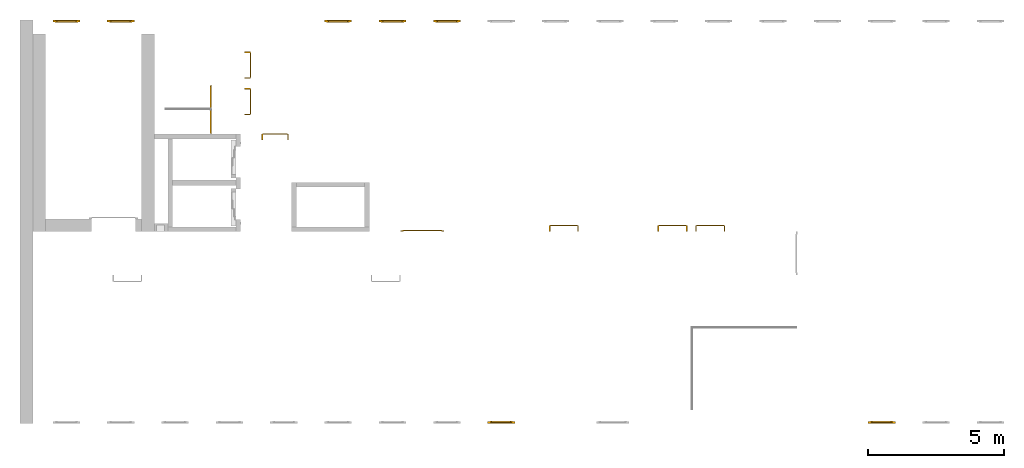
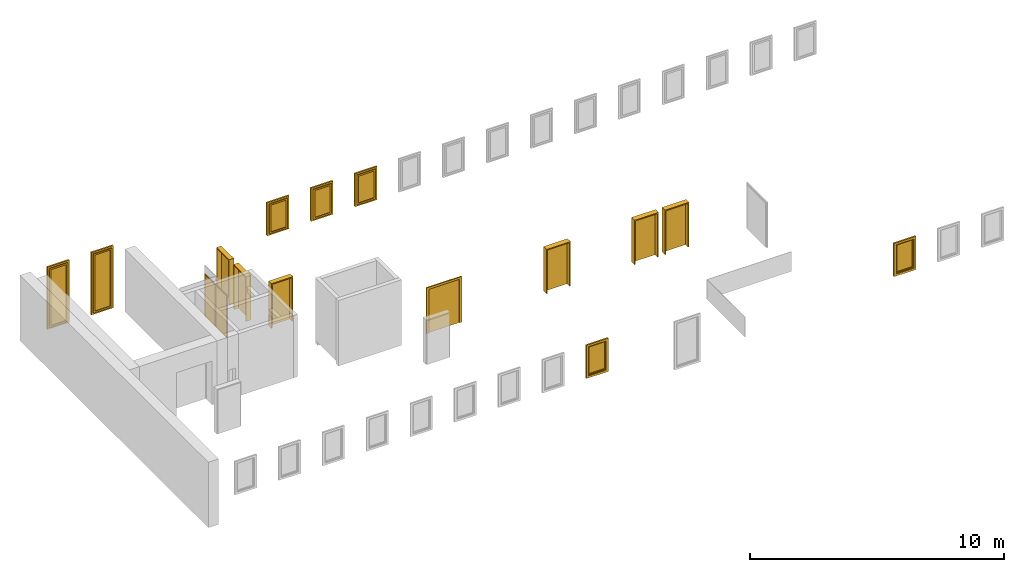
# One storey, part 3 of 5: 9 doors, 7 windows.
"""IFC4 building model written with IfcOpenShell, lengths in metres."""

from ifc_helpers import new_model, entity, si_unit, converted_unit, derived_unit, direction, frame, origin_with_axes, place, context, subcontext, project, spatial, polygons, source, transform, mapped, type_object, element, save


model = new_model("IFC4")

# Units and contexts
model_context = context("Model", 3, precision=1e-05, world=origin_with_axes(), true_north=direction((0.0, 1.0)))
body_context = subcontext(model_context, "Body", "Model", "MODEL_VIEW")
ifc_project = project(units=[si_unit("LENGTHUNIT", "METRE"), si_unit("AREAUNIT", "SQUARE_METRE"), si_unit("VOLUMEUNIT", "CUBIC_METRE"), converted_unit("PLANEANGLEUNIT", "DEGREE", entity("IfcPlaneAngleMeasure", 0.0174532925199433), si_unit("PLANEANGLEUNIT", "RADIAN"), dimensions=[0, 0, 0, 0, 0, 0, 0]), converted_unit("TIMEUNIT", "Year", entity("IfcTimeMeasure", 31557600.0), si_unit("TIMEUNIT", "SECOND"), dimensions=[0, 0, 1, 0, 0, 0, 0]), si_unit("MASSUNIT", "GRAM", prefix="KILO"), si_unit("THERMODYNAMICTEMPERATUREUNIT", "DEGREE_CELSIUS"), si_unit("LUMINOUSINTENSITYUNIT", "LUMEN"), si_unit("ENERGYUNIT", "JOULE", prefix="MEGA"), derived_unit("THERMALCONDUCTANCEUNIT", [(si_unit("POWERUNIT", "WATT"), 1), (si_unit("LENGTHUNIT", "METRE"), -1), (si_unit("THERMODYNAMICTEMPERATUREUNIT", "KELVIN"), -1)]), derived_unit("SPECIFICHEATCAPACITYUNIT", [(si_unit("ENERGYUNIT", "JOULE"), 1), (si_unit("MASSUNIT", "GRAM", prefix="KILO"), -1), (si_unit("THERMODYNAMICTEMPERATUREUNIT", "KELVIN"), -1)]), derived_unit("MASSDENSITYUNIT", [(si_unit("MASSUNIT", "GRAM", prefix="KILO"), 1), (si_unit("VOLUMEUNIT", "CUBIC_METRE"), -1)])], contexts=[model_context])

# Site, building, storey
site_placement = place(None, origin_with_axes())
site = spatial("IfcSite", under=ifc_project, at=site_placement, CompositionType="ELEMENT")
building_placement = place(None, origin_with_axes())
building = spatial("IfcBuilding", under=site, at=building_placement, CompositionType="ELEMENT")
storey_placement = place(None, frame((0.0, 0.0, 4.5), z_axis=(0.0, 0.0, 1.0), x_axis=(1.0, 0.0, 0.0)))
storey = spatial("IfcBuildingStorey", under=building, at=storey_placement, Name="1 OG", CompositionType="ELEMENT", Elevation=4.5)

# Windows
window_type = type_object("IfcWindowType", Name="1-27", PartitioningType="SINGLE_PANEL", PredefinedType="WINDOW")
shared_shape_1 = source(origin_with_axes(), body_context, "Body", "Tessellation", [
    polygons([(-0.5, -0.07, 0.0), (-0.5, 0.0, 0.0), (-0.4, 0.0, 0.1), (-0.4, -0.07, 0.1), (-0.5, -0.07, 1.6), (-0.5, 0.0, 1.6), (-0.4, 0.0, 1.5), (-0.4, -0.07, 1.5)], [[[1, 2, 3, 4]], [[5, 6, 2, 1]], [[2, 6, 7, 3]], [[4, 3, 7, 8]], [[1, 4, 8, 5]], [[8, 7, 6, 5]]], closed=True),
    polygons([(0.5, -0.07, 0.0), (0.5, 0.0, 0.0), (0.5, 0.0, 1.6), (0.5, -0.07, 1.6), (0.4, -0.07, 0.1), (0.4, 0.0, 0.1), (0.4, 0.0, 1.5), (0.4, -0.07, 1.5)], [[[1, 2, 3, 4]], [[5, 6, 2, 1]], [[2, 6, 7, 3]], [[4, 3, 7, 8]], [[1, 4, 8, 5]], [[8, 7, 6, 5]]], closed=True),
    polygons([(-0.5, -0.07, 0.0), (-0.5, 0.0, 0.0), (0.5, 0.0, 0.0), (0.5, -0.07, 0.0), (-0.4, -0.07, 0.1), (-0.4, 0.0, 0.1), (0.0, 0.0, 0.1), (0.4, 0.0, 0.1), (0.4, -0.07, 0.1), (0.0, -0.07, 0.1)], [[[1, 2, 3, 4]], [[5, 6, 2, 1]], [[2, 6, 7, 8, 3]], [[4, 3, 8, 9]], [[1, 4, 9, 10, 5]], [[10, 7, 6, 5]], [[9, 8, 7, 10]]], closed=True),
    polygons([(-0.5, -0.07, 1.6), (-0.5, 0.0, 1.6), (-0.4, 0.0, 1.5), (-0.4, -0.07, 1.5), (0.5, -0.07, 1.6), (0.5, 0.0, 1.6), (0.4, 0.0, 1.5), (0.0, 0.0, 1.5), (0.0, -0.07, 1.5), (0.4, -0.07, 1.5)], [[[1, 2, 3, 4]], [[5, 6, 2, 1]], [[2, 6, 7, 8, 3]], [[4, 3, 8, 9]], [[1, 4, 9, 10, 5]], [[10, 7, 6, 5]], [[9, 8, 7, 10]]], closed=True),
    polygons([(-0.42, 0.0, 0.08), (-0.42, 0.03, 0.08), (-0.35, 0.03, 0.15), (-0.35, 0.0, 0.15), (-0.42, 0.0, 1.52), (-0.42, 0.03, 1.52), (-0.35, 0.03, 1.45), (-0.35, 0.0, 1.45)], [[[1, 2, 3, 4]], [[5, 6, 2, 1]], [[2, 6, 7, 3]], [[4, 3, 7, 8]], [[1, 4, 8, 5]], [[8, 7, 6, 5]]], closed=True),
    polygons([(0.42, 0.0, 0.08), (0.35, 0.0, 0.15), (0.35, 0.03, 0.15), (0.42, 0.03, 0.08), (0.42, 0.0, 1.52), (0.35, 0.0, 1.45), (0.35, 0.03, 1.45), (0.42, 0.03, 1.52)], [[[1, 2, 3, 4]], [[1, 5, 6, 2]], [[2, 6, 7, 3]], [[4, 3, 7, 8]], [[5, 1, 4, 8]], [[6, 5, 8, 7]]], closed=True),
    polygons([(-0.42, 0.0, 0.08), (-0.42, 0.03, 0.08), (0.42, 0.03, 0.08), (0.42, 0.0, 0.08), (-0.35, 0.0, 0.15), (-0.35, 0.03, 0.15), (0.35, 0.03, 0.15), (0.35, 0.0, 0.15)], [[[1, 2, 3, 4]], [[5, 6, 2, 1]], [[2, 6, 7, 3]], [[4, 3, 7, 8]], [[1, 4, 8, 5]], [[8, 7, 6, 5]]], closed=True),
    polygons([(-0.42, 0.0, 1.52), (0.42, 0.0, 1.52), (0.42, 0.03, 1.52), (-0.42, 0.03, 1.52), (-0.35, 0.0, 1.45), (0.35, 0.0, 1.45), (0.35, 0.03, 1.45), (-0.35, 0.03, 1.45)], [[[1, 2, 3, 4]], [[1, 5, 6, 2]], [[2, 6, 7, 3]], [[4, 3, 7, 8]], [[5, 1, 4, 8]], [[6, 5, 8, 7]]], closed=True),
    polygons([(-0.4, -0.03, 0.1), (-0.4, 0.0, 0.1), (-0.35, 0.0, 0.15), (-0.35, -0.03, 0.15), (-0.4, -0.03, 1.5), (-0.4, 0.0, 1.5), (-0.35, 0.0, 1.45), (-0.35, -0.03, 1.45)], [[[1, 2, 3, 4]], [[5, 6, 2, 1]], [[2, 6, 7, 3]], [[4, 3, 7, 8]], [[1, 4, 8, 5]], [[8, 7, 6, 5]]], closed=True),
    polygons([(0.4, -0.03, 0.1), (0.35, -0.03, 0.15), (0.35, 0.0, 0.15), (0.4, 0.0, 0.1), (0.4, -0.03, 1.5), (0.35, -0.03, 1.45), (0.35, 0.0, 1.45), (0.4, 0.0, 1.5)], [[[1, 2, 3, 4]], [[1, 5, 6, 2]], [[2, 6, 7, 3]], [[4, 3, 7, 8]], [[5, 1, 4, 8]], [[6, 5, 8, 7]]], closed=True),
    polygons([(-0.4, -0.03, 0.1), (-0.4, 0.0, 0.1), (0.4, 0.0, 0.1), (0.4, -0.03, 0.1), (-0.35, -0.03, 0.15), (-0.35, 0.0, 0.15), (0.35, 0.0, 0.15), (0.35, -0.03, 0.15)], [[[1, 2, 3, 4]], [[5, 6, 2, 1]], [[2, 6, 7, 3]], [[4, 3, 7, 8]], [[1, 4, 8, 5]], [[8, 7, 6, 5]]], closed=True),
    polygons([(-0.4, -0.03, 1.5), (0.4, -0.03, 1.5), (0.4, 0.0, 1.5), (-0.4, 0.0, 1.5), (-0.35, -0.03, 1.45), (0.35, -0.03, 1.45), (0.35, 0.0, 1.45), (-0.35, 0.0, 1.45)], [[[1, 2, 3, 4]], [[1, 5, 6, 2]], [[2, 6, 7, 3]], [[4, 3, 7, 8]], [[5, 1, 4, 8]], [[6, 5, 8, 7]]], closed=True),
    polygons([(-0.35, -0.00500000000000001, 0.15), (-0.35, 0.00499999999999999, 0.15), (0.35, 0.00499999999999999, 0.15), (0.35, -0.00500000000000001, 0.15), (-0.35, -0.00500000000000001, 1.45), (-0.35, 0.00499999999999999, 1.45), (0.35, 0.00499999999999999, 1.45), (0.35, -0.00500000000000001, 1.45)], [[[1, 2, 3, 4]], [[5, 6, 2, 1]], [[2, 6, 7, 3]], [[4, 3, 7, 8]], [[1, 4, 8, 5]], [[8, 7, 6, 5]]], closed=True),
])
window_1_placement = place(None, frame((54.723, 0.0, 5.5), z_axis=(0.0, 0.0, 1.0), x_axis=(1.0, 0.0, 0.0)))
element("IfcWindow", 1, at=window_1_placement, inside=storey, type_object=window_type, Name="Fenster-001", OverallHeight=1.6, OverallWidth=1.0, context=body_context, shape_type="MappedRepresentation", body=[
    mapped(shared_shape_1, transform((0.5, 0.0700000000000006, 0.0))),
])
window_2_placement = place(None, frame((40.723, 0.0, 5.5), z_axis=(0.0, 0.0, 1.0), x_axis=(1.0, 0.0, 0.0)))
element("IfcWindow", 2, at=window_2_placement, inside=storey, type_object=window_type, Name="Fenster-001", OverallHeight=1.6, OverallWidth=1.0, context=body_context, shape_type="MappedRepresentation", body=[
    mapped(shared_shape_1, transform((0.5, 0.0700000000000013, 0.0))),
])
shared_shape_2 = source(origin_with_axes(), body_context, "Body", "Tessellation", [
    polygons([(0.5, -0.07, 0.0), (0.4, -0.07, 0.1), (0.4, 0.0, 0.1), (0.5, 0.0, 0.0), (0.5, -0.07, 1.6), (0.4, -0.07, 1.5), (0.4, 0.0, 1.5), (0.5, 0.0, 1.6)], [[[1, 2, 3, 4]], [[1, 5, 6, 2]], [[2, 6, 7, 3]], [[4, 3, 7, 8]], [[5, 1, 4, 8]], [[6, 5, 8, 7]]], closed=True),
    polygons([(-0.5, -0.07, 0.0), (-0.5, -0.07, 1.6), (-0.5, 0.0, 1.6), (-0.5, 0.0, 0.0), (-0.4, -0.07, 0.1), (-0.4, -0.07, 1.5), (-0.4, 0.0, 1.5), (-0.4, 0.0, 0.1)], [[[1, 2, 3, 4]], [[1, 5, 6, 2]], [[2, 6, 7, 3]], [[4, 3, 7, 8]], [[5, 1, 4, 8]], [[6, 5, 8, 7]]], closed=True),
    polygons([(0.5, -0.07, 0.0), (-0.5, -0.07, 0.0), (-0.5, 0.0, 0.0), (0.5, 0.0, 0.0), (0.4, -0.07, 0.1), (0.0, -0.07, 0.1), (-0.4, -0.07, 0.1), (-0.4, 0.0, 0.1), (0.0, 0.0, 0.1), (0.4, 0.0, 0.1)], [[[1, 2, 3, 4]], [[1, 5, 6, 7, 2]], [[2, 7, 8, 3]], [[4, 3, 8, 9, 10]], [[5, 1, 4, 10]], [[6, 5, 10, 9]], [[7, 6, 9, 8]]], closed=True),
    polygons([(0.5, -0.07, 1.6), (0.4, -0.07, 1.5), (0.4, 0.0, 1.5), (0.5, 0.0, 1.6), (-0.5, -0.07, 1.6), (-0.4, -0.07, 1.5), (0.0, -0.07, 1.5), (0.0, 0.0, 1.5), (-0.4, 0.0, 1.5), (-0.5, 0.0, 1.6)], [[[1, 2, 3, 4]], [[1, 5, 6, 7, 2]], [[2, 7, 8, 3]], [[4, 3, 8, 9, 10]], [[5, 1, 4, 10]], [[6, 5, 10, 9]], [[7, 6, 9, 8]]], closed=True),
    polygons([(0.42, 0.0, 0.08), (0.35, 0.0, 0.15), (0.35, 0.03, 0.15), (0.42, 0.03, 0.08), (0.42, 0.0, 1.52), (0.35, 0.0, 1.45), (0.35, 0.03, 1.45), (0.42, 0.03, 1.52)], [[[1, 2, 3, 4]], [[1, 5, 6, 2]], [[2, 6, 7, 3]], [[4, 3, 7, 8]], [[5, 1, 4, 8]], [[6, 5, 8, 7]]], closed=True),
    polygons([(-0.42, 0.0, 0.08), (-0.42, 0.03, 0.08), (-0.35, 0.03, 0.15), (-0.35, 0.0, 0.15), (-0.42, 0.0, 1.52), (-0.42, 0.03, 1.52), (-0.35, 0.03, 1.45), (-0.35, 0.0, 1.45)], [[[1, 2, 3, 4]], [[5, 6, 2, 1]], [[2, 6, 7, 3]], [[4, 3, 7, 8]], [[1, 4, 8, 5]], [[8, 7, 6, 5]]], closed=True),
    polygons([(0.42, 0.0, 0.08), (-0.42, 0.0, 0.08), (-0.42, 0.03, 0.08), (0.42, 0.03, 0.08), (0.35, 0.0, 0.15), (-0.35, 0.0, 0.15), (-0.35, 0.03, 0.15), (0.35, 0.03, 0.15)], [[[1, 2, 3, 4]], [[1, 5, 6, 2]], [[2, 6, 7, 3]], [[4, 3, 7, 8]], [[5, 1, 4, 8]], [[6, 5, 8, 7]]], closed=True),
    polygons([(0.42, 0.0, 1.52), (0.42, 0.03, 1.52), (-0.42, 0.03, 1.52), (-0.42, 0.0, 1.52), (0.35, 0.0, 1.45), (0.35, 0.03, 1.45), (-0.35, 0.03, 1.45), (-0.35, 0.0, 1.45)], [[[1, 2, 3, 4]], [[5, 6, 2, 1]], [[2, 6, 7, 3]], [[4, 3, 7, 8]], [[1, 4, 8, 5]], [[8, 7, 6, 5]]], closed=True),
    polygons([(0.4, -0.03, 0.1), (0.35, -0.03, 0.15), (0.35, 0.0, 0.15), (0.4, 0.0, 0.1), (0.4, -0.03, 1.5), (0.35, -0.03, 1.45), (0.35, 0.0, 1.45), (0.4, 0.0, 1.5)], [[[1, 2, 3, 4]], [[1, 5, 6, 2]], [[2, 6, 7, 3]], [[4, 3, 7, 8]], [[5, 1, 4, 8]], [[6, 5, 8, 7]]], closed=True),
    polygons([(-0.4, -0.03, 0.1), (-0.4, 0.0, 0.1), (-0.35, 0.0, 0.15), (-0.35, -0.03, 0.15), (-0.4, -0.03, 1.5), (-0.4, 0.0, 1.5), (-0.35, 0.0, 1.45), (-0.35, -0.03, 1.45)], [[[1, 2, 3, 4]], [[5, 6, 2, 1]], [[2, 6, 7, 3]], [[4, 3, 7, 8]], [[1, 4, 8, 5]], [[8, 7, 6, 5]]], closed=True),
    polygons([(0.4, -0.03, 0.1), (-0.4, -0.03, 0.1), (-0.4, 0.0, 0.1), (0.4, 0.0, 0.1), (0.35, -0.03, 0.15), (-0.35, -0.03, 0.15), (-0.35, 0.0, 0.15), (0.35, 0.0, 0.15)], [[[1, 2, 3, 4]], [[1, 5, 6, 2]], [[2, 6, 7, 3]], [[4, 3, 7, 8]], [[5, 1, 4, 8]], [[6, 5, 8, 7]]], closed=True),
    polygons([(0.4, -0.03, 1.5), (0.4, 0.0, 1.5), (-0.4, 0.0, 1.5), (-0.4, -0.03, 1.5), (0.35, -0.03, 1.45), (0.35, 0.0, 1.45), (-0.35, 0.0, 1.45), (-0.35, -0.03, 1.45)], [[[1, 2, 3, 4]], [[5, 6, 2, 1]], [[2, 6, 7, 3]], [[4, 3, 7, 8]], [[1, 4, 8, 5]], [[8, 7, 6, 5]]], closed=True),
    polygons([(0.35, -0.00500000000000001, 0.15), (-0.35, -0.00500000000000001, 0.15), (-0.35, 0.00499999999999999, 0.15), (0.35, 0.00499999999999999, 0.15), (0.35, -0.00500000000000001, 1.45), (-0.35, -0.00500000000000001, 1.45), (-0.35, 0.00499999999999999, 1.45), (0.35, 0.00499999999999999, 1.45)], [[[1, 2, 3, 4]], [[1, 5, 6, 2]], [[2, 6, 7, 3]], [[4, 3, 7, 8]], [[5, 1, 4, 8]], [[6, 5, 8, 7]]], closed=True),
])
for number, where, z_axis, x_axis, name in (
    (3, (35.723, 14.8459998909351, 5.5), (0.0, 0.0, 1.0), (-1.0, 0.0, 0.0), "Fenster-001"),
    (4, (37.723, 14.8459998909351, 5.5), (0.0, 0.0, 1.0), (-1.0, 0.0, 0.0), "Fenster-001"),
    (5, (39.723, 14.8459998909351, 5.5), (0.0, 0.0, 1.0), (-1.0, 0.0, 0.0), "Fenster-001"),
):
    element("IfcWindow", number, at=place(None, frame(where, z_axis=z_axis, x_axis=x_axis)), inside=storey, type_object=window_type, Name=name, OverallHeight=1.6, OverallWidth=1.0, context=body_context, shape_type="MappedRepresentation", body=[
        mapped(shared_shape_2, transform((0.5, 0.0699999999999985, 0.0))),
    ])

# Doors
door_type_1 = type_object("IfcDoorType", Name="27", OperationType="SINGLE_SWING_RIGHT", PredefinedType="DOOR")
shared_shape_3 = source(origin_with_axes(), body_context, "Body", "Tessellation", [
    polygons([(0.545, -0.2325, 0.0), (0.545, -0.025, 0.0), (0.545, -0.025, 2.145), (0.545, -0.2325, 2.145), (0.5, -0.2325, 0.0), (0.5, -0.025, 0.0), (0.5, -0.025, 2.1), (0.0551, -0.025, 2.1), (0.0001, -0.025, 2.1), (-0.5, -0.025, 2.1), (-0.5, -0.025, 0.0), (-0.545, -0.025, 0.0), (-0.545, -0.025, 2.145), (-0.545, -0.2325, 2.145), (-0.545, -0.2325, 0.0), (-0.5, -0.2325, 0.0), (-0.5, -0.2325, 2.1), (0.0001, -0.2325, 2.1), (0.0551, -0.2325, 2.1), (0.5, -0.2325, 2.1)], [[[1, 2, 3, 4]], [[5, 6, 2, 1]], [[2, 6, 7, 8, 9, 10, 11, 12, 13, 3]], [[4, 3, 13, 14]], [[1, 4, 14, 15, 16, 17, 18, 19, 20, 5]], [[20, 7, 6, 5]], [[19, 8, 7, 20]], [[18, 9, 8, 19]], [[17, 10, 9, 18]], [[16, 11, 10, 17]], [[15, 12, 11, 16]], [[14, 13, 12, 15]]], closed=True),
    polygons([(0.545, -0.025, 0.0), (0.545, 0.0, 0.0), (0.545, 0.0, 2.145), (0.545, -0.025, 2.145), (0.51, -0.025, 0.0), (0.51, 0.0, 0.0), (0.51, 0.0, 2.11), (0.0451, 0.0, 2.11), (0.0101, 0.0, 2.11), (-0.51, 0.0, 2.11), (-0.51, 0.0, 0.0), (-0.545, 0.0, 0.0), (-0.545, 0.0, 2.145), (-0.545, -0.025, 2.145), (-0.545, -0.025, 0.0), (-0.51, -0.025, 0.0), (-0.51, -0.025, 2.11), (0.0101, -0.025, 2.11), (0.0451, -0.025, 2.11), (0.51, -0.025, 2.11)], [[[1, 2, 3, 4]], [[5, 6, 2, 1]], [[2, 6, 7, 8, 9, 10, 11, 12, 13, 3]], [[4, 3, 13, 14]], [[1, 4, 14, 15, 16, 17, 18, 19, 20, 5]], [[20, 7, 6, 5]], [[19, 8, 7, 20]], [[18, 9, 8, 19]], [[17, 10, 9, 18]], [[16, 11, 10, 17]], [[15, 12, 11, 16]], [[14, 13, 12, 15]]], closed=True),
    polygons([(0.51, 0.015, 0.0), (-0.51, 0.015, 0.0), (-0.51, 0.015, 2.11), (0.51, 0.015, 2.11), (0.51, -0.025, 0.0), (-0.51, -0.025, 0.0), (-0.51, -0.025, 2.11), (0.51, -0.025, 2.11)], [[[1, 2, 3, 4]], [[2, 1, 5, 6]], [[3, 2, 6, 7]], [[4, 3, 7, 8]], [[1, 4, 8, 5]], [[6, 5, 8, 7]]], closed=True),
])
door_1_placement = place(None, frame((43.028, 7.05499994546756, 4.5), z_axis=(0.0, 0.0, 1.0), x_axis=(1.0, 0.0, 0.0)))
element("IfcDoor", 6, at=door_1_placement, inside=storey, type_object=door_type_1, OverallHeight=2.145, OverallWidth=1.09, context=body_context, shape_type="MappedRepresentation", body=[
    mapped(shared_shape_3, transform((0.5, 0.232500000000002, 0.0))),
])
door_2_placement = place(None, frame((47.028, 7.05499994546756, 4.5), z_axis=(0.0, 0.0, 1.0), x_axis=(1.0, 0.0, 0.0)))
element("IfcDoor", 7, at=door_2_placement, inside=storey, type_object=door_type_1, OverallHeight=2.145, OverallWidth=1.09, context=body_context, shape_type="MappedRepresentation", body=[
    mapped(shared_shape_3, transform((0.5, 0.232500000000001, 0.0))),
])

# Space
space_placement = place(None, frame((28.883, 12.4404999136732, 4.5), z_axis=(0.0, 0.0, 1.0), x_axis=(0.0, -1.0, 0.0)))
space = spatial("IfcSpace", under=storey, at=space_placement, CompositionType="ELEMENT", PredefinedType="NOTDEFINED")

# Doors
door_type_2 = type_object("IfcDoorType", Name="27", OperationType="SINGLE_SWING_LEFT", PredefinedType="DOOR")
shared_shape_4 = source(origin_with_axes(), body_context, "Body", "Tessellation", [
    polygons([(-0.445, -0.025, 0.0), (-0.445, -0.025, 2.045), (-0.445, 0.0, 2.045), (-0.445, 0.0, 0.0), (-0.41, -0.025, 0.0), (-0.41, -0.025, 2.01), (-0.0451, -0.025, 2.01), (-0.0101, -0.025, 2.01), (0.41, -0.025, 2.01), (0.41, -0.025, 0.0), (0.445, -0.025, 0.0), (0.445, -0.025, 2.045), (0.445, 0.0, 2.045), (0.445, 0.0, 0.0), (0.41, 0.0, 0.0), (0.41, 0.0, 2.01), (-0.0101, 0.0, 2.01), (-0.0451, 0.0, 2.01), (-0.41, 0.0, 2.01), (-0.41, 0.0, 0.0)], [[[1, 2, 3, 4]], [[1, 5, 6, 7, 8, 9, 10, 11, 12, 2]], [[2, 12, 13, 3]], [[4, 3, 13, 14, 15, 16, 17, 18, 19, 20]], [[5, 1, 4, 20]], [[6, 5, 20, 19]], [[7, 6, 19, 18]], [[8, 7, 18, 17]], [[9, 8, 17, 16]], [[10, 9, 16, 15]], [[11, 10, 15, 14]], [[12, 11, 14, 13]]], closed=True),
    polygons([(-0.41, 0.015, 0.0), (-0.41, 0.015, 2.01), (0.41, 0.015, 2.01), (0.41, 0.015, 0.0), (-0.41, -0.025, 0.0), (-0.41, -0.025, 2.01), (0.41, -0.025, 2.01), (0.41, -0.025, 0.0)], [[[1, 2, 3, 4]], [[1, 5, 6, 2]], [[2, 6, 7, 3]], [[3, 7, 8, 4]], [[4, 8, 5, 1]], [[8, 7, 6, 5]]], closed=True),
])
door_3_placement = place(None, frame((30.553, 10.6999999454676, 4.55), z_axis=(0.0, 0.0, 1.0), x_axis=(0.0, 1.0, 0.0)))
element("IfcDoor", 8, at=door_3_placement, inside=space, type_object=door_type_2, OverallHeight=2.095, OverallWidth=0.89, context=body_context, shape_type="MappedRepresentation", body=[
    mapped(shared_shape_4, transform((0.4, 0.0199999999999996, 0.0))),
])
door_type_3 = type_object("IfcDoorType", Name="2-Fl 27", OperationType="DOUBLE_DOOR_SINGLE_SWING", PredefinedType="DOOR")
shared_shape_5 = source(origin_with_axes(), body_context, "Body", "Tessellation", [
    polygons([(0.8, -0.05, 0.0), (0.8, -0.02, 0.0), (0.8, -0.02, 2.2), (0.8, -0.05, 2.2), (0.7, -0.05, 0.0), (0.7, -0.02, 0.0), (0.7, -0.02, 2.1), (0.1251, -0.02, 2.1), (0.0001, -0.02, 2.1), (-0.7, -0.02, 2.1), (-0.7, -0.02, 0.0), (-0.8, -0.02, 0.0), (-0.8, -0.02, 2.2), (-0.8, -0.05, 2.2), (-0.8, -0.05, 0.0), (-0.7, -0.05, 0.0), (-0.7, -0.05, 2.1), (0.0001, -0.05, 2.1), (0.1251, -0.05, 2.1), (0.7, -0.05, 2.1)], [[[1, 2, 3, 4]], [[5, 6, 2, 1]], [[2, 6, 7, 8, 9, 10, 11, 12, 13, 3]], [[4, 3, 13, 14]], [[1, 4, 14, 15, 16, 17, 18, 19, 20, 5]], [[20, 7, 6, 5]], [[19, 8, 7, 20]], [[18, 9, 8, 19]], [[17, 10, 9, 18]], [[16, 11, 10, 17]], [[15, 12, 11, 16]], [[14, 13, 12, 15]]], closed=True),
    polygons([(0.8, -0.02, 0.0), (0.8, 0.0, 0.0), (0.8, 0.0, 2.2), (0.8, -0.02, 2.2), (0.725, -0.02, 0.0), (0.725, 0.0, 0.0), (0.725, 0.0, 2.125), (0.1001, 0.0, 2.125), (0.0251, 0.0, 2.125), (-0.725, 0.0, 2.125), (-0.725, 0.0, 0.0), (-0.8, 0.0, 0.0), (-0.8, 0.0, 2.2), (-0.8, -0.02, 2.2), (-0.8, -0.02, 0.0), (-0.725, -0.02, 0.0), (-0.725, -0.02, 2.125), (0.0251, -0.02, 2.125), (0.1001, -0.02, 2.125), (0.725, -0.02, 2.125)], [[[1, 2, 3, 4]], [[5, 6, 2, 1]], [[2, 6, 7, 8, 9, 10, 11, 12, 13, 3]], [[4, 3, 13, 14]], [[1, 4, 14, 15, 16, 17, 18, 19, 20, 5]], [[20, 7, 6, 5]], [[19, 8, 7, 20]], [[18, 9, 8, 19]], [[17, 10, 9, 18]], [[16, 11, 10, 17]], [[15, 12, 11, 16]], [[14, 13, 12, 15]]], closed=True),
    polygons([(0.725, 0.02, 0.0), (0.000499999999999945, 0.02, 0.0), (0.000499999999999945, 0.02, 2.125), (0.725, 0.02, 2.125), (0.725, -0.02, 0.0), (0.000499999999999945, -0.02, 0.0), (0.000499999999999945, -0.02, 2.125), (0.725, -0.02, 2.125)], [[[1, 2, 3, 4]], [[2, 1, 5, 6]], [[3, 2, 6, 7]], [[4, 3, 7, 8]], [[1, 4, 8, 5]], [[6, 5, 8, 7]]], closed=True),
    polygons([(-0.725, 0.02, 0.0), (-0.725, 0.02, 2.125), (-0.000499999999999945, 0.02, 2.125), (-0.000499999999999945, 0.02, 0.0), (-0.725, -0.02, 0.0), (-0.725, -0.02, 2.125), (-0.000499999999999945, -0.02, 2.125), (-0.000499999999999945, -0.02, 0.0)], [[[1, 2, 3, 4]], [[1, 5, 6, 2]], [[2, 6, 7, 3]], [[3, 7, 8, 4]], [[4, 8, 5, 1]], [[8, 7, 6, 5]]], closed=True),
])
door_4_placement = place(None, frame((37.622, 7.05499994546756, 4.5), z_axis=(0.0, 0.0, 1.0), x_axis=(1.0, 0.0, 0.0)))
element("IfcDoor", 9, at=door_4_placement, inside=storey, type_object=door_type_3, OverallHeight=2.2, OverallWidth=1.6, context=body_context, shape_type="MappedRepresentation", body=[
    mapped(shared_shape_5, transform((0.700000000000003, 0.0499999999999998, 0.0))),
])
shared_shape_6 = source(origin_with_axes(), body_context, "Body", "Tessellation", [
    polygons([(-0.495, -0.218, 0.0), (-0.495, -0.218, 2.145), (-0.495, -0.025, 2.145), (-0.495, -0.025, 0.0), (-0.45, -0.218, 0.0), (-0.45, -0.218, 2.1), (-0.0551, -0.218, 2.1), (-0.0001, -0.218, 2.1), (0.45, -0.218, 2.1), (0.45, -0.218, 0.0), (0.495, -0.218, 0.0), (0.495, -0.218, 2.145), (0.495, -0.025, 2.145), (0.495, -0.025, 0.0), (0.45, -0.025, 0.0), (0.45, -0.025, 2.1), (-0.0001, -0.025, 2.1), (-0.0551, -0.025, 2.1), (-0.45, -0.025, 2.1), (-0.45, -0.025, 0.0)], [[[1, 2, 3, 4]], [[1, 5, 6, 7, 8, 9, 10, 11, 12, 2]], [[2, 12, 13, 3]], [[4, 3, 13, 14, 15, 16, 17, 18, 19, 20]], [[5, 1, 4, 20]], [[6, 5, 20, 19]], [[7, 6, 19, 18]], [[8, 7, 18, 17]], [[9, 8, 17, 16]], [[10, 9, 16, 15]], [[11, 10, 15, 14]], [[12, 11, 14, 13]]], closed=True),
    polygons([(-0.495, -0.025, 0.0), (-0.495, -0.025, 2.145), (-0.495, 0.0, 2.145), (-0.495, 0.0, 0.0), (-0.46, -0.025, 0.0), (-0.46, -0.025, 2.11), (-0.0451, -0.025, 2.11), (-0.0101, -0.025, 2.11), (0.46, -0.025, 2.11), (0.46, -0.025, 0.0), (0.495, -0.025, 0.0), (0.495, -0.025, 2.145), (0.495, 0.0, 2.145), (0.495, 0.0, 0.0), (0.46, 0.0, 0.0), (0.46, 0.0, 2.11), (-0.0101, 0.0, 2.11), (-0.0451, 0.0, 2.11), (-0.46, 0.0, 2.11), (-0.46, 0.0, 0.0)], [[[1, 2, 3, 4]], [[1, 5, 6, 7, 8, 9, 10, 11, 12, 2]], [[2, 12, 13, 3]], [[4, 3, 13, 14, 15, 16, 17, 18, 19, 20]], [[5, 1, 4, 20]], [[6, 5, 20, 19]], [[7, 6, 19, 18]], [[8, 7, 18, 17]], [[9, 8, 17, 16]], [[10, 9, 16, 15]], [[11, 10, 15, 14]], [[12, 11, 14, 13]]], closed=True),
    polygons([(-0.46, 0.015, 0.0), (-0.46, 0.015, 2.11), (0.46, 0.015, 2.11), (0.46, 0.015, 0.0), (-0.46, -0.025, 0.0), (-0.46, -0.025, 2.11), (0.46, -0.025, 2.11), (0.46, -0.025, 0.0)], [[[1, 2, 3, 4]], [[1, 5, 6, 2]], [[2, 6, 7, 3]], [[3, 7, 8, 4]], [[4, 8, 5, 1]], [[8, 7, 6, 5]]], closed=True),
])
for number, where, z_axis, x_axis in (
    (10, (32.005, 12.2904999136732, 4.5), (0.0, 0.0, 1.0), (0.0, -1.0, 0.0)),
    (11, (32.005, 13.6354999136732, 4.5), (0.0, 0.0, 1.0), (0.0, -1.0, 0.0)),
):
    element("IfcDoor", number, at=place(None, frame(where, z_axis=z_axis, x_axis=x_axis)), inside=storey, type_object=door_type_2, OverallHeight=2.145, OverallWidth=0.99, context=body_context, shape_type="MappedRepresentation", body=[
        mapped(shared_shape_6, transform((0.449999999999999, 0.0, 0.0))),
    ])
shared_shape_7 = source(origin_with_axes(), body_context, "Body", "Tessellation", [
    polygons([(0.445, -0.025, 0.0), (0.445, 0.0, 0.0), (0.445, 0.0, 2.045), (0.445, -0.025, 2.045), (0.41, -0.025, 0.0), (0.41, 0.0, 0.0), (0.41, 0.0, 2.01), (0.0451, 0.0, 2.01), (0.0101, 0.0, 2.01), (-0.41, 0.0, 2.01), (-0.41, 0.0, 0.0), (-0.445, 0.0, 0.0), (-0.445, 0.0, 2.045), (-0.445, -0.025, 2.045), (-0.445, -0.025, 0.0), (-0.41, -0.025, 0.0), (-0.41, -0.025, 2.01), (0.0101, -0.025, 2.01), (0.0451, -0.025, 2.01), (0.41, -0.025, 2.01)], [[[1, 2, 3, 4]], [[5, 6, 2, 1]], [[2, 6, 7, 8, 9, 10, 11, 12, 13, 3]], [[4, 3, 13, 14]], [[1, 4, 14, 15, 16, 17, 18, 19, 20, 5]], [[20, 7, 6, 5]], [[19, 8, 7, 20]], [[18, 9, 8, 19]], [[17, 10, 9, 18]], [[16, 11, 10, 17]], [[15, 12, 11, 16]], [[14, 13, 12, 15]]], closed=True),
    polygons([(0.41, 0.015, 0.0), (-0.41, 0.015, 0.0), (-0.41, 0.015, 2.01), (0.41, 0.015, 2.01), (0.41, -0.025, 0.0), (-0.41, -0.025, 0.0), (-0.41, -0.025, 2.01), (0.41, -0.025, 2.01)], [[[1, 2, 3, 4]], [[2, 1, 5, 6]], [[3, 2, 6, 7]], [[4, 3, 7, 8]], [[1, 4, 8, 5]], [[6, 5, 8, 7]]], closed=True),
])
door_5_placement = place(None, frame((30.553, 11.5954999136732, 4.55), z_axis=(0.0, 0.0, 1.0), x_axis=(0.0, 1.0, 0.0)))
element("IfcDoor", 12, at=door_5_placement, inside=space, type_object=door_type_1, OverallHeight=2.095, OverallWidth=0.89, context=body_context, shape_type="MappedRepresentation", body=[
    mapped(shared_shape_7, transform((0.4, 0.0199999999999996, 0.0))),
])
shared_shape_8 = source(origin_with_axes(), body_context, "Body", "Tessellation", [
    polygons([(0.495, -0.218, 0.0), (0.495, -0.025, 0.0), (0.495, -0.025, 2.145), (0.495, -0.218, 2.145), (0.45, -0.218, 0.0), (0.45, -0.025, 0.0), (0.45, -0.025, 2.1), (0.0551, -0.025, 2.1), (0.0001, -0.025, 2.1), (-0.45, -0.025, 2.1), (-0.45, -0.025, 0.0), (-0.495, -0.025, 0.0), (-0.495, -0.025, 2.145), (-0.495, -0.218, 2.145), (-0.495, -0.218, 0.0), (-0.45, -0.218, 0.0), (-0.45, -0.218, 2.1), (0.0001, -0.218, 2.1), (0.0551, -0.218, 2.1), (0.45, -0.218, 2.1)], [[[1, 2, 3, 4]], [[5, 6, 2, 1]], [[2, 6, 7, 8, 9, 10, 11, 12, 13, 3]], [[4, 3, 13, 14]], [[1, 4, 14, 15, 16, 17, 18, 19, 20, 5]], [[20, 7, 6, 5]], [[19, 8, 7, 20]], [[18, 9, 8, 19]], [[17, 10, 9, 18]], [[16, 11, 10, 17]], [[15, 12, 11, 16]], [[14, 13, 12, 15]]], closed=True),
    polygons([(0.495, -0.025, 0.0), (0.495, 0.0, 0.0), (0.495, 0.0, 2.145), (0.495, -0.025, 2.145), (0.46, -0.025, 0.0), (0.46, 0.0, 0.0), (0.46, 0.0, 2.11), (0.0451, 0.0, 2.11), (0.0101, 0.0, 2.11), (-0.46, 0.0, 2.11), (-0.46, 0.0, 0.0), (-0.495, 0.0, 0.0), (-0.495, 0.0, 2.145), (-0.495, -0.025, 2.145), (-0.495, -0.025, 0.0), (-0.46, -0.025, 0.0), (-0.46, -0.025, 2.11), (0.0101, -0.025, 2.11), (0.0451, -0.025, 2.11), (0.46, -0.025, 2.11)], [[[1, 2, 3, 4]], [[5, 6, 2, 1]], [[2, 6, 7, 8, 9, 10, 11, 12, 13, 3]], [[4, 3, 13, 14]], [[1, 4, 14, 15, 16, 17, 18, 19, 20, 5]], [[20, 7, 6, 5]], [[19, 8, 7, 20]], [[18, 9, 8, 19]], [[17, 10, 9, 18]], [[16, 11, 10, 17]], [[15, 12, 11, 16]], [[14, 13, 12, 15]]], closed=True),
    polygons([(0.46, 0.015, 0.0), (-0.46, 0.015, 0.0), (-0.46, 0.015, 2.11), (0.46, 0.015, 2.11), (0.46, -0.025, 0.0), (-0.46, -0.025, 0.0), (-0.46, -0.025, 2.11), (0.46, -0.025, 2.11)], [[[1, 2, 3, 4]], [[2, 1, 5, 6]], [[3, 2, 6, 7]], [[4, 3, 7, 8]], [[1, 4, 8, 5]], [[6, 5, 8, 7]]], closed=True),
])
door_6_placement = place(None, frame((32.455, 10.6549999454676, 4.5), z_axis=(0.0, 0.0, 1.0), x_axis=(1.0, 0.0, 0.0)))
element("IfcDoor", 13, at=door_6_placement, inside=storey, type_object=door_type_1, OverallHeight=2.145, OverallWidth=0.99, context=body_context, shape_type="MappedRepresentation", body=[
    mapped(shared_shape_8, transform((0.450000000000003, 0.0, 0.0))),
])
shared_shape_9 = source(origin_with_axes(), body_context, "Body", "Tessellation", [
    polygons([(-0.545, -0.2325, 0.0), (-0.545, -0.2325, 2.145), (-0.545, -0.025, 2.145), (-0.545, -0.025, 0.0), (-0.5, -0.2325, 0.0), (-0.5, -0.2325, 2.1), (-0.0551, -0.2325, 2.1), (-0.0001, -0.2325, 2.1), (0.5, -0.2325, 2.1), (0.5, -0.2325, 0.0), (0.545, -0.2325, 0.0), (0.545, -0.2325, 2.145), (0.545, -0.025, 2.145), (0.545, -0.025, 0.0), (0.5, -0.025, 0.0), (0.5, -0.025, 2.1), (-0.0001, -0.025, 2.1), (-0.0551, -0.025, 2.1), (-0.5, -0.025, 2.1), (-0.5, -0.025, 0.0)], [[[1, 2, 3, 4]], [[1, 5, 6, 7, 8, 9, 10, 11, 12, 2]], [[2, 12, 13, 3]], [[4, 3, 13, 14, 15, 16, 17, 18, 19, 20]], [[5, 1, 4, 20]], [[6, 5, 20, 19]], [[7, 6, 19, 18]], [[8, 7, 18, 17]], [[9, 8, 17, 16]], [[10, 9, 16, 15]], [[11, 10, 15, 14]], [[12, 11, 14, 13]]], closed=True),
    polygons([(-0.545, -0.025, 0.0), (-0.545, -0.025, 2.145), (-0.545, 0.0, 2.145), (-0.545, 0.0, 0.0), (-0.51, -0.025, 0.0), (-0.51, -0.025, 2.11), (-0.0451, -0.025, 2.11), (-0.0101, -0.025, 2.11), (0.51, -0.025, 2.11), (0.51, -0.025, 0.0), (0.545, -0.025, 0.0), (0.545, -0.025, 2.145), (0.545, 0.0, 2.145), (0.545, 0.0, 0.0), (0.51, 0.0, 0.0), (0.51, 0.0, 2.11), (-0.0101, 0.0, 2.11), (-0.0451, 0.0, 2.11), (-0.51, 0.0, 2.11), (-0.51, 0.0, 0.0)], [[[1, 2, 3, 4]], [[1, 5, 6, 7, 8, 9, 10, 11, 12, 2]], [[2, 12, 13, 3]], [[4, 3, 13, 14, 15, 16, 17, 18, 19, 20]], [[5, 1, 4, 20]], [[6, 5, 20, 19]], [[7, 6, 19, 18]], [[8, 7, 18, 17]], [[9, 8, 17, 16]], [[10, 9, 16, 15]], [[11, 10, 15, 14]], [[12, 11, 14, 13]]], closed=True),
    polygons([(-0.51, 0.015, 0.0), (-0.51, 0.015, 2.11), (0.51, 0.015, 2.11), (0.51, 0.015, 0.0), (-0.51, -0.025, 0.0), (-0.51, -0.025, 2.11), (0.51, -0.025, 2.11), (0.51, -0.025, 0.0)], [[[1, 2, 3, 4]], [[1, 5, 6, 2]], [[2, 6, 7, 3]], [[3, 7, 8, 4]], [[4, 8, 5, 1]], [[8, 7, 6, 5]]], closed=True),
])
door_7_placement = place(None, frame((48.418, 7.05499994546756, 4.5), z_axis=(0.0, 0.0, 1.0), x_axis=(1.0, 0.0, 0.0)))
element("IfcDoor", 14, at=door_7_placement, inside=storey, type_object=door_type_2, OverallHeight=2.145, OverallWidth=1.09, context=body_context, shape_type="MappedRepresentation", body=[
    mapped(shared_shape_9, transform((0.5, 0.232500000000002, 0.0))),
])

# Windows
shared_shape_10 = source(origin_with_axes(), body_context, "Body", "Tessellation", [
    polygons([(0.5, -0.07, 0.0), (0.4, -0.07, 0.1), (0.4, 0.0, 0.1), (0.5, 0.0, 0.0), (0.5, -0.07, 3.0), (0.4, -0.07, 2.9), (0.4, 0.0, 2.9), (0.5, 0.0, 3.0)], [[[1, 2, 3, 4]], [[1, 5, 6, 2]], [[2, 6, 7, 3]], [[4, 3, 7, 8]], [[5, 1, 4, 8]], [[6, 5, 8, 7]]], closed=True),
    polygons([(-0.5, -0.07, 0.0), (-0.5, -0.07, 3.0), (-0.5, 0.0, 3.0), (-0.5, 0.0, 0.0), (-0.4, -0.07, 0.1), (-0.4, -0.07, 2.9), (-0.4, 0.0, 2.9), (-0.4, 0.0, 0.1)], [[[1, 2, 3, 4]], [[1, 5, 6, 2]], [[2, 6, 7, 3]], [[4, 3, 7, 8]], [[5, 1, 4, 8]], [[6, 5, 8, 7]]], closed=True),
    polygons([(0.5, -0.07, 0.0), (-0.5, -0.07, 0.0), (-0.5, 0.0, 0.0), (0.5, 0.0, 0.0), (0.4, -0.07, 0.1), (0.0, -0.07, 0.1), (-0.4, -0.07, 0.1), (-0.4, 0.0, 0.1), (0.0, 0.0, 0.1), (0.4, 0.0, 0.1)], [[[1, 2, 3, 4]], [[1, 5, 6, 7, 2]], [[2, 7, 8, 3]], [[4, 3, 8, 9, 10]], [[5, 1, 4, 10]], [[6, 5, 10, 9]], [[7, 6, 9, 8]]], closed=True),
    polygons([(0.5, -0.07, 3.0), (0.4, -0.07, 2.9), (0.4, 0.0, 2.9), (0.5, 0.0, 3.0), (-0.5, -0.07, 3.0), (-0.4, -0.07, 2.9), (0.0, -0.07, 2.9), (0.0, 0.0, 2.9), (-0.4, 0.0, 2.9), (-0.5, 0.0, 3.0)], [[[1, 2, 3, 4]], [[1, 5, 6, 7, 2]], [[2, 7, 8, 3]], [[4, 3, 8, 9, 10]], [[5, 1, 4, 10]], [[6, 5, 10, 9]], [[7, 6, 9, 8]]], closed=True),
    polygons([(0.42, 0.0, 0.08), (0.35, 0.0, 0.15), (0.35, 0.03, 0.15), (0.42, 0.03, 0.08), (0.42, 0.0, 2.92), (0.35, 0.0, 2.85), (0.35, 0.03, 2.85), (0.42, 0.03, 2.92)], [[[1, 2, 3, 4]], [[1, 5, 6, 2]], [[2, 6, 7, 3]], [[4, 3, 7, 8]], [[5, 1, 4, 8]], [[6, 5, 8, 7]]], closed=True),
    polygons([(-0.42, 0.0, 0.08), (-0.42, 0.03, 0.08), (-0.35, 0.03, 0.15), (-0.35, 0.0, 0.15), (-0.42, 0.0, 2.92), (-0.42, 0.03, 2.92), (-0.35, 0.03, 2.85), (-0.35, 0.0, 2.85)], [[[1, 2, 3, 4]], [[5, 6, 2, 1]], [[2, 6, 7, 3]], [[4, 3, 7, 8]], [[1, 4, 8, 5]], [[8, 7, 6, 5]]], closed=True),
    polygons([(0.42, 0.0, 0.08), (-0.42, 0.0, 0.08), (-0.42, 0.03, 0.08), (0.42, 0.03, 0.08), (0.35, 0.0, 0.15), (-0.35, 0.0, 0.15), (-0.35, 0.03, 0.15), (0.35, 0.03, 0.15)], [[[1, 2, 3, 4]], [[1, 5, 6, 2]], [[2, 6, 7, 3]], [[4, 3, 7, 8]], [[5, 1, 4, 8]], [[6, 5, 8, 7]]], closed=True),
    polygons([(0.42, 0.0, 2.92), (0.42, 0.03, 2.92), (-0.42, 0.03, 2.92), (-0.42, 0.0, 2.92), (0.35, 0.0, 2.85), (0.35, 0.03, 2.85), (-0.35, 0.03, 2.85), (-0.35, 0.0, 2.85)], [[[1, 2, 3, 4]], [[5, 6, 2, 1]], [[2, 6, 7, 3]], [[4, 3, 7, 8]], [[1, 4, 8, 5]], [[8, 7, 6, 5]]], closed=True),
    polygons([(0.4, -0.03, 0.1), (0.35, -0.03, 0.15), (0.35, 0.0, 0.15), (0.4, 0.0, 0.1), (0.4, -0.03, 2.9), (0.35, -0.03, 2.85), (0.35, 0.0, 2.85), (0.4, 0.0, 2.9)], [[[1, 2, 3, 4]], [[1, 5, 6, 2]], [[2, 6, 7, 3]], [[4, 3, 7, 8]], [[5, 1, 4, 8]], [[6, 5, 8, 7]]], closed=True),
    polygons([(-0.4, -0.03, 0.1), (-0.4, 0.0, 0.1), (-0.35, 0.0, 0.15), (-0.35, -0.03, 0.15), (-0.4, -0.03, 2.9), (-0.4, 0.0, 2.9), (-0.35, 0.0, 2.85), (-0.35, -0.03, 2.85)], [[[1, 2, 3, 4]], [[5, 6, 2, 1]], [[2, 6, 7, 3]], [[4, 3, 7, 8]], [[1, 4, 8, 5]], [[8, 7, 6, 5]]], closed=True),
    polygons([(0.4, -0.03, 0.1), (-0.4, -0.03, 0.1), (-0.4, 0.0, 0.1), (0.4, 0.0, 0.1), (0.35, -0.03, 0.15), (-0.35, -0.03, 0.15), (-0.35, 0.0, 0.15), (0.35, 0.0, 0.15)], [[[1, 2, 3, 4]], [[1, 5, 6, 2]], [[2, 6, 7, 3]], [[4, 3, 7, 8]], [[5, 1, 4, 8]], [[6, 5, 8, 7]]], closed=True),
    polygons([(0.4, -0.03, 2.9), (0.4, 0.0, 2.9), (-0.4, 0.0, 2.9), (-0.4, -0.03, 2.9), (0.35, -0.03, 2.85), (0.35, 0.0, 2.85), (-0.35, 0.0, 2.85), (-0.35, -0.03, 2.85)], [[[1, 2, 3, 4]], [[5, 6, 2, 1]], [[2, 6, 7, 3]], [[4, 3, 7, 8]], [[1, 4, 8, 5]], [[8, 7, 6, 5]]], closed=True),
    polygons([(0.35, -0.00500000000000001, 0.15), (-0.35, -0.00500000000000001, 0.15), (-0.35, 0.00499999999999999, 0.15), (0.35, 0.00499999999999999, 0.15), (0.35, -0.00500000000000001, 2.85), (-0.35, -0.00500000000000001, 2.85), (-0.35, 0.00499999999999999, 2.85), (0.35, 0.00499999999999999, 2.85)], [[[1, 2, 3, 4]], [[1, 5, 6, 2]], [[2, 6, 7, 3]], [[4, 3, 7, 8]], [[5, 1, 4, 8]], [[6, 5, 8, 7]]], closed=True),
])
for number, where, z_axis, x_axis, name in (
    (15, (27.723, 14.8459998909351, 4.5), (0.0, 0.0, 1.0), (-1.0, 0.0, 0.0), "Fenster-001"),
    (16, (25.723, 14.8459998909351, 4.5), (0.0, 0.0, 1.0), (-1.0, 0.0, 0.0), "Fenster-001"),
):
    element("IfcWindow", number, at=place(None, frame(where, z_axis=z_axis, x_axis=x_axis)), inside=storey, type_object=window_type, Name=name, OverallHeight=3.0, OverallWidth=1.0, context=body_context, shape_type="MappedRepresentation", body=[
        mapped(shared_shape_10, transform((0.5, 0.0699999999999967, 0.0))),
    ])

save(model, "model.ifc")
